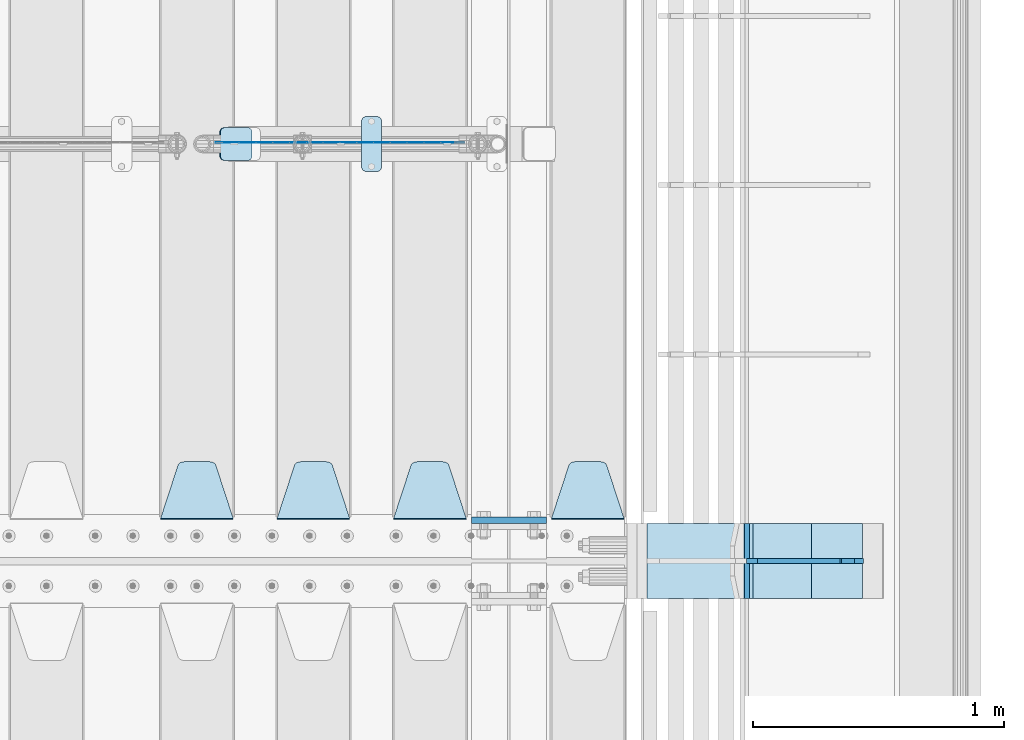
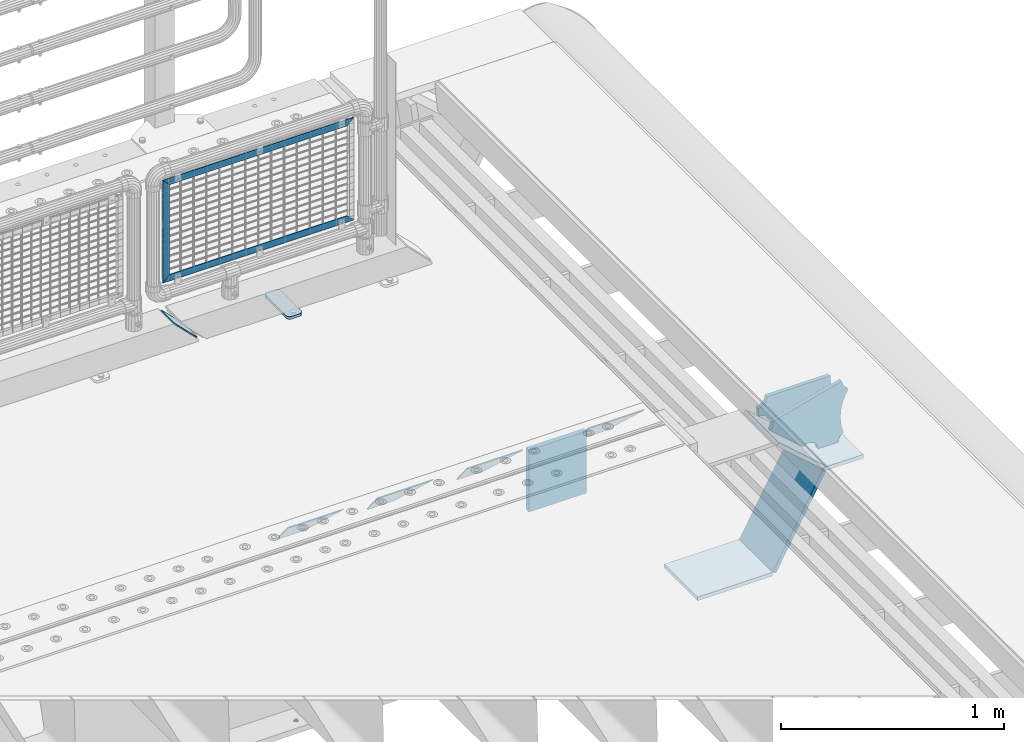
# One storey, part 191 of 208: 16 plates.
"""IFC2X3 building model written with IfcOpenShell, lengths in millimetres."""

from ifc_helpers import new_model, si_unit, frame, origin_with_axes, place, context, subcontext, project, spatial, faceted_brep, material, type_object, element, save


model = new_model("IFC2X3")

# Units and contexts
model_context = context("Model", 3, precision=1e-05, world=origin_with_axes())
body_context = subcontext(model_context, "Body", "Model", "MODEL_VIEW")
ifc_project = project(units=[si_unit("LENGTHUNIT", "METRE", prefix="MILLI"), si_unit("AREAUNIT", "SQUARE_METRE"), si_unit("VOLUMEUNIT", "CUBIC_METRE"), si_unit("MASSUNIT", "GRAM", prefix="KILO"), si_unit("TIMEUNIT", "SECOND"), si_unit("PLANEANGLEUNIT", "RADIAN"), si_unit("SOLIDANGLEUNIT", "STERADIAN"), si_unit("THERMODYNAMICTEMPERATUREUNIT", "DEGREE_CELSIUS"), si_unit("LUMINOUSINTENSITYUNIT", "LUMEN")], contexts=[model_context])

# Site, building, storey
site_placement = place(None, origin_with_axes())
site = spatial("IfcSite", under=ifc_project, at=site_placement, CompositionType="ELEMENT")
building_placement = place(site_placement, origin_with_axes())
building = spatial("IfcBuilding", under=site, at=building_placement, Name="Standard", CompositionType="ELEMENT")
storey_placement = place(building_placement, origin_with_axes())
storey = spatial("IfcBuildingStorey", under=building, at=storey_placement, Name="Undefined", CompositionType="ELEMENT", Elevation=0.0)

# Plates
ifc_material_1 = material(Name="STEEL/S355N")
plate_type_1 = type_object("IfcPlateType", PredefinedType="NOTDEFINED")
plate_1_placement = place(storey_placement, frame((-26255.0, 3162.5, -340.000000000044), z_axis=(0.0, 0.0, 1.0), x_axis=(1.0, 0.0, 0.0)))
element("IfcPlate", 1, at=plate_1_placement, inside=storey, type_object=plate_type_1, material=ifc_material_1, context=body_context, shape_type="Brep", body=[
    faceted_brep([(0.0, -12.5, 0.0), (0.0, -12.5, 340.0), (0.0, 12.5, 340.0), (0.0, 12.5, 0.0), (300.0, -12.5, 340.0), (300.0, 12.5, 340.0), (300.0, -12.5, 0.0), (300.0, 12.5, 0.0)], [[[0, 1, 2, 3]], [[1, 4, 5, 2]], [[4, 6, 7, 5]], [[6, 0, 3, 7]], [[5, 7, 3, 2]], [[6, 4, 1, 0]]]),
])
ifc_material_2 = material(Name="STEEL/S355J2")
plate_type_2 = type_object("IfcPlateType", PredefinedType="NOTDEFINED")
plate_2_placement = place(storey_placement, frame((-26693.0, 4774.5, 21.0199999999977), z_axis=(1.0, 0.0, 0.0), x_axis=(0.0, -1.0, 0.0)))
element("IfcPlate", 2, at=plate_2_placement, inside=storey, type_object=plate_type_2, material=ifc_material_2, context=body_context, shape_type="Brep", body=[
    faceted_brep([(0.0, -7.0, 20.0), (0.0, -7.0, 60.0), (0.0, 7.0, 60.0), (0.0, 7.0, 20.0), (0.384294391935327, -7.0, 63.9018064403208), (0.384294391935327, 7.0, 63.9018064403208), (1.52240934977453, -7.0, 67.6536686473009), (1.52240934977453, 7.0, 67.6536686473009), (3.37060775394912, -7.0, 71.1114046603907), (3.37060775394912, 7.0, 71.1114046603907), (5.85786437626939, -7.0, 74.1421356237297), (5.85786437626939, 7.0, 74.1421356237297), (8.8885953396084, -7.0, 76.62939224605), (8.8885953396084, 7.0, 76.62939224605), (12.3463313526981, -7.0, 78.4775906502255), (12.3463313526981, 7.0, 78.4775906502255), (16.0981935596774, -7.0, 79.6157056080629), (16.0981935596774, 7.0, 79.6157056080629), (20.0, -7.0, 80.0), (20.0, 7.0, 80.0), (200.0, -7.0, 80.0), (200.0, 7.0, 80.0), (203.901806440323, -7.0, 79.6157056080629), (203.901806440323, 7.0, 79.6157056080629), (207.653668647302, -7.0, 78.4775906502255), (207.653668647302, 7.0, 78.4775906502255), (211.111404660393, -7.0, 76.62939224605), (211.111404660393, 7.0, 76.62939224605), (214.142135623731, -7.0, 74.1421356237297), (214.142135623731, 7.0, 74.1421356237297), (216.629392246051, -7.0, 71.1114046603907), (216.629392246051, 7.0, 71.1114046603907), (218.477590650225, -7.0, 67.6536686473009), (218.477590650225, 7.0, 67.6536686473009), (219.615705608065, -7.0, 63.9018064403208), (219.615705608065, 7.0, 63.9018064403208), (220.0, -7.0, 60.0), (220.0, 7.0, 60.0), (220.0, -7.0, 20.0), (220.0, 7.0, 20.0), (219.615705608065, -7.0, 16.0981935596792), (219.615705608065, 7.0, 16.0981935596792), (218.477590650225, -7.0, 12.3463313526991), (218.477590650225, 7.0, 12.3463313526991), (216.629392246051, -7.0, 8.88859533960931), (216.629392246051, 7.0, 8.88859533960931), (214.142135623731, -7.0, 5.8578643762703), (214.142135623731, 7.0, 5.8578643762703), (211.111404660393, -7.0, 3.37060775395003), (211.111404660393, 7.0, 3.37060775395003), (207.653668647302, -7.0, 1.52240934977453), (207.653668647302, 7.0, 1.52240934977453), (203.901806440323, -7.0, 0.384294391937146), (203.901806440323, 7.0, 0.384294391937146), (200.0, -7.0, 0.0), (200.0, 7.0, 0.0), (20.0, -7.0, 0.0), (20.0, 7.0, 0.0), (16.0981935596774, -7.0, 0.384294391937146), (16.0981935596774, 7.0, 0.384294391937146), (12.3463313526981, -7.0, 1.52240934977453), (12.3463313526981, 7.0, 1.52240934977453), (8.8885953396084, -7.0, 3.37060775395003), (8.8885953396084, 7.0, 3.37060775395003), (5.85786437626939, -7.0, 5.8578643762703), (5.85786437626939, 7.0, 5.8578643762703), (3.37060775394912, -7.0, 8.88859533960931), (3.37060775394912, 7.0, 8.88859533960931), (1.52240934977453, -7.0, 12.3463313526991), (1.52240934977453, 7.0, 12.3463313526991), (0.384294391935327, -7.0, 16.0981935596792), (0.384294391935327, 7.0, 16.0981935596792)], [[[0, 1, 2, 3]], [[1, 4, 5, 2]], [[4, 6, 7, 5]], [[6, 8, 9, 7]], [[8, 10, 11, 9]], [[10, 12, 13, 11]], [[12, 14, 15, 13]], [[14, 16, 17, 15]], [[16, 18, 19, 17]], [[18, 20, 21, 19]], [[20, 22, 23, 21]], [[22, 24, 25, 23]], [[24, 26, 27, 25]], [[26, 28, 29, 27]], [[28, 30, 31, 29]], [[30, 32, 33, 31]], [[32, 34, 35, 33]], [[34, 36, 37, 35]], [[36, 38, 39, 37]], [[38, 40, 41, 39]], [[40, 42, 43, 41]], [[42, 44, 45, 43]], [[44, 46, 47, 45]], [[46, 48, 49, 47]], [[48, 50, 51, 49]], [[50, 52, 53, 51]], [[52, 54, 55, 53]], [[54, 56, 57, 55]], [[56, 58, 59, 57]], [[58, 60, 61, 59]], [[60, 62, 63, 61]], [[62, 64, 65, 63]], [[64, 66, 67, 65]], [[66, 68, 69, 67]], [[68, 70, 71, 69]], [[70, 0, 3, 71]], [[5, 7, 9, 11, 13, 15, 17, 19, 21, 23, 25, 27, 29, 31, 33, 35, 37, 39, 41, 43, 45, 47, 49, 51, 53, 55, 57, 59, 61, 63, 65, 67, 69, 71, 3, 2]], [[70, 68, 66, 64, 62, 60, 58, 56, 54, 52, 50, 48, 46, 44, 42, 40, 38, 36, 34, 32, 30, 28, 26, 24, 22, 20, 18, 16, 14, 12, 10, 8, 6, 4, 1, 0]]]),
])
plate_type_3 = type_object("IfcPlateType", PredefinedType="NOTDEFINED")
plate_3_placement = place(storey_placement, frame((-25645.0, 3168.23223304702, -1.76776695296758), z_axis=(0.0, 0.707106781186547, -0.707106781186548), x_axis=(-1.0, 0.0, 0.0)))
element("IfcPlate", 3, at=plate_3_placement, inside=storey, type_object=plate_type_3, material=ifc_material_1, context=body_context, shape_type="Brep", body=[
    faceted_brep([(0.0, -2.5, 0.0), (69.345504679477, -2.5, 300.17173142483), (69.345504679477, 2.5, 300.17173142483), (0.0, 2.5, 0.0), (70.9274061199576, -2.5, 304.897442415399), (70.9274061199576, 2.5, 304.8974424154), (73.3818627772307, -2.5, 309.234538108527), (73.3818627772307, 2.5, 309.234538108527), (76.6187032999551, -2.5, 313.023683126103), (76.6187032999551, 2.5, 313.023683126103), (80.5190132704993, -2.5, 316.125672595371), (80.5190132704993, 2.5, 316.125672595371), (84.9395038596849, -2.5, 318.426546230476), (84.9395038596849, 2.50000000000091, 318.426546230476), (89.7177759439219, -2.5, 319.841774983275), (89.7177759439219, 2.50000000000091, 319.841774983275), (94.678286292652, -2.49999999999909, 320.319366455078), (94.678286292652, 2.5, 320.319366455078), (195.321713707348, -2.49999999999909, 320.319366455078), (195.321713707348, 2.5, 320.319366455078), (200.282224056078, -2.5, 319.841774983275), (200.282224056078, 2.5, 319.841774983274), (205.060496140315, -2.5, 318.426546230475), (205.060496140315, 2.5, 318.426546230475), (209.480986729501, -2.5, 316.125672595371), (209.480986729501, 2.50000000000091, 316.125672595371), (213.381296700045, -2.5, 313.023683126102), (213.381296700045, 2.5, 313.023683126102), (216.618137222769, -2.5, 309.234538108526), (216.618137222769, 2.5, 309.234538108527), (219.072593880042, -2.5, 304.897442415399), (219.072593880042, 2.5, 304.897442415399), (220.654495320523, -2.5, 300.17173142483), (220.654495320523, 2.5, 300.17173142483), (290.0, -2.5, 0.0), (290.0, 2.5, 0.0)], [[[0, 1, 2, 3]], [[1, 4, 5, 2]], [[4, 6, 7, 5]], [[6, 8, 9, 7]], [[8, 10, 11, 9]], [[10, 12, 13, 11]], [[12, 14, 15, 13]], [[14, 16, 17, 15]], [[16, 18, 19, 17]], [[18, 20, 21, 19]], [[20, 22, 23, 21]], [[22, 24, 25, 23]], [[24, 26, 27, 25]], [[26, 28, 29, 27]], [[28, 30, 31, 29]], [[30, 32, 33, 31]], [[32, 34, 35, 33]], [[34, 0, 3, 35]], [[5, 7, 9, 11, 13, 15, 17, 19, 21, 23, 25, 27, 29, 31, 33, 35, 3, 2]], [[34, 32, 30, 28, 26, 24, 22, 20, 18, 16, 14, 12, 10, 8, 6, 4, 1, 0]]]),
])
plate_4_placement = place(storey_placement, frame((-26275.0, 3168.23223304702, -1.76776695296758), z_axis=(0.0, 0.707106781186547, -0.707106781186548), x_axis=(-1.0, 0.0, 0.0)))
element("IfcPlate", 4, at=plate_4_placement, inside=storey, type_object=plate_type_3, material=ifc_material_1, context=body_context, shape_type="Brep", body=[
    faceted_brep([(0.0, -2.5, 0.0), (69.345504679477, -2.5, 300.17173142483), (69.345504679477, 2.5, 300.17173142483), (0.0, 2.5, 0.0), (70.9274061199576, -2.5, 304.897442415399), (70.9274061199576, 2.5, 304.8974424154), (73.3818627772307, -2.5, 309.234538108527), (73.3818627772307, 2.5, 309.234538108527), (76.6187032999551, -2.5, 313.023683126103), (76.6187032999551, 2.5, 313.023683126103), (80.5190132704993, -2.5, 316.125672595371), (80.5190132704993, 2.5, 316.125672595371), (84.9395038596849, -2.5, 318.426546230476), (84.9395038596849, 2.50000000000091, 318.426546230476), (89.7177759439219, -2.5, 319.841774983275), (89.7177759439219, 2.50000000000091, 319.841774983275), (94.678286292652, -2.49999999999909, 320.319366455078), (94.678286292652, 2.5, 320.319366455078), (195.321713707348, -2.49999999999909, 320.319366455078), (195.321713707348, 2.5, 320.319366455078), (200.282224056078, -2.5, 319.841774983275), (200.282224056078, 2.5, 319.841774983274), (205.060496140315, -2.5, 318.426546230475), (205.060496140315, 2.5, 318.426546230475), (209.480986729501, -2.5, 316.125672595371), (209.480986729501, 2.50000000000091, 316.125672595371), (213.381296700045, -2.5, 313.023683126102), (213.381296700045, 2.5, 313.023683126102), (216.618137222769, -2.5, 309.234538108526), (216.618137222769, 2.5, 309.234538108527), (219.072593880042, -2.5, 304.897442415399), (219.072593880042, 2.5, 304.897442415399), (220.654495320523, -2.5, 300.17173142483), (220.654495320523, 2.5, 300.17173142483), (290.0, -2.5, 0.0), (290.0, 2.5, 0.0)], [[[0, 1, 2, 3]], [[1, 4, 5, 2]], [[4, 6, 7, 5]], [[6, 8, 9, 7]], [[8, 10, 11, 9]], [[10, 12, 13, 11]], [[12, 14, 15, 13]], [[14, 16, 17, 15]], [[16, 18, 19, 17]], [[18, 20, 21, 19]], [[20, 22, 23, 21]], [[22, 24, 25, 23]], [[24, 26, 27, 25]], [[26, 28, 29, 27]], [[28, 30, 31, 29]], [[30, 32, 33, 31]], [[32, 34, 35, 33]], [[34, 0, 3, 35]], [[5, 7, 9, 11, 13, 15, 17, 19, 21, 23, 25, 27, 29, 31, 33, 35, 3, 2]], [[34, 32, 30, 28, 26, 24, 22, 20, 18, 16, 14, 12, 10, 8, 6, 4, 1, 0]]]),
])
plate_5_placement = place(storey_placement, frame((-26740.0, 3168.23223304702, -1.76776695296758), z_axis=(0.0, 0.707106781186547, -0.707106781186548), x_axis=(-1.0, 0.0, 0.0)))
element("IfcPlate", 5, at=plate_5_placement, inside=storey, type_object=plate_type_3, material=ifc_material_1, context=body_context, shape_type="Brep", body=[
    faceted_brep([(0.0, -2.5, 0.0), (69.345504679477, -2.5, 300.17173142483), (69.345504679477, 2.5, 300.17173142483), (0.0, 2.5, 0.0), (70.9274061199576, -2.5, 304.897442415399), (70.9274061199576, 2.5, 304.8974424154), (73.3818627772307, -2.5, 309.234538108527), (73.3818627772307, 2.5, 309.234538108527), (76.6187032999551, -2.5, 313.023683126103), (76.6187032999551, 2.5, 313.023683126103), (80.5190132704993, -2.5, 316.125672595371), (80.5190132704993, 2.5, 316.125672595371), (84.9395038596849, -2.5, 318.426546230476), (84.9395038596849, 2.50000000000091, 318.426546230476), (89.7177759439219, -2.5, 319.841774983275), (89.7177759439219, 2.50000000000091, 319.841774983275), (94.678286292652, -2.49999999999909, 320.319366455078), (94.678286292652, 2.5, 320.319366455078), (195.321713707348, -2.49999999999909, 320.319366455078), (195.321713707348, 2.5, 320.319366455078), (200.282224056078, -2.5, 319.841774983275), (200.282224056078, 2.5, 319.841774983274), (205.060496140315, -2.5, 318.426546230475), (205.060496140315, 2.5, 318.426546230475), (209.480986729501, -2.5, 316.125672595371), (209.480986729501, 2.50000000000091, 316.125672595371), (213.381296700045, -2.5, 313.023683126102), (213.381296700045, 2.5, 313.023683126102), (216.618137222769, -2.5, 309.234538108526), (216.618137222769, 2.5, 309.234538108527), (219.072593880042, -2.5, 304.897442415399), (219.072593880042, 2.5, 304.897442415399), (220.654495320523, -2.5, 300.17173142483), (220.654495320523, 2.5, 300.17173142483), (290.0, -2.5, 0.0), (290.0, 2.5, 0.0)], [[[0, 1, 2, 3]], [[1, 4, 5, 2]], [[4, 6, 7, 5]], [[6, 8, 9, 7]], [[8, 10, 11, 9]], [[10, 12, 13, 11]], [[12, 14, 15, 13]], [[14, 16, 17, 15]], [[16, 18, 19, 17]], [[18, 20, 21, 19]], [[20, 22, 23, 21]], [[22, 24, 25, 23]], [[24, 26, 27, 25]], [[26, 28, 29, 27]], [[28, 30, 31, 29]], [[30, 32, 33, 31]], [[32, 34, 35, 33]], [[34, 0, 3, 35]], [[5, 7, 9, 11, 13, 15, 17, 19, 21, 23, 25, 27, 29, 31, 33, 35, 3, 2]], [[34, 32, 30, 28, 26, 24, 22, 20, 18, 16, 14, 12, 10, 8, 6, 4, 1, 0]]]),
])
plate_6_placement = place(storey_placement, frame((-27205.0, 3168.23223304702, -1.76776695296758), z_axis=(0.0, 0.707106781186547, -0.707106781186548), x_axis=(-1.0, 0.0, 0.0)))
element("IfcPlate", 6, at=plate_6_placement, inside=storey, type_object=plate_type_3, material=ifc_material_1, context=body_context, shape_type="Brep", body=[
    faceted_brep([(0.0, -2.5, 0.0), (69.345504679477, -2.5, 300.17173142483), (69.345504679477, 2.5, 300.17173142483), (0.0, 2.5, 0.0), (70.9274061199576, -2.5, 304.897442415399), (70.9274061199576, 2.5, 304.8974424154), (73.3818627772307, -2.5, 309.234538108527), (73.3818627772307, 2.5, 309.234538108527), (76.6187032999551, -2.5, 313.023683126103), (76.6187032999551, 2.5, 313.023683126103), (80.5190132704993, -2.5, 316.125672595371), (80.5190132704993, 2.5, 316.125672595371), (84.9395038596849, -2.5, 318.426546230476), (84.9395038596849, 2.50000000000091, 318.426546230476), (89.7177759439219, -2.5, 319.841774983275), (89.7177759439219, 2.50000000000091, 319.841774983275), (94.678286292652, -2.49999999999909, 320.319366455078), (94.678286292652, 2.5, 320.319366455078), (195.321713707348, -2.49999999999909, 320.319366455078), (195.321713707348, 2.5, 320.319366455078), (200.282224056078, -2.5, 319.841774983275), (200.282224056078, 2.5, 319.841774983274), (205.060496140315, -2.5, 318.426546230475), (205.060496140315, 2.5, 318.426546230475), (209.480986729501, -2.5, 316.125672595371), (209.480986729501, 2.50000000000091, 316.125672595371), (213.381296700045, -2.5, 313.023683126102), (213.381296700045, 2.5, 313.023683126102), (216.618137222769, -2.5, 309.234538108526), (216.618137222769, 2.5, 309.234538108527), (219.072593880042, -2.5, 304.897442415399), (219.072593880042, 2.5, 304.897442415399), (220.654495320523, -2.5, 300.17173142483), (220.654495320523, 2.5, 300.17173142483), (290.0, -2.5, 0.0), (290.0, 2.5, 0.0)], [[[0, 1, 2, 3]], [[1, 4, 5, 2]], [[4, 6, 7, 5]], [[6, 8, 9, 7]], [[8, 10, 11, 9]], [[10, 12, 13, 11]], [[12, 14, 15, 13]], [[14, 16, 17, 15]], [[16, 18, 19, 17]], [[18, 20, 21, 19]], [[20, 22, 23, 21]], [[22, 24, 25, 23]], [[24, 26, 27, 25]], [[26, 28, 29, 27]], [[28, 30, 31, 29]], [[30, 32, 33, 31]], [[32, 34, 35, 33]], [[34, 0, 3, 35]], [[5, 7, 9, 11, 13, 15, 17, 19, 21, 23, 25, 27, 29, 31, 33, 35, 3, 2]], [[34, 32, 30, 28, 26, 24, 22, 20, 18, 16, 14, 12, 10, 8, 6, 4, 1, 0]]]),
])
ifc_material_3 = material(Name="Misc_Undefined")
plate_type_4 = type_object("IfcPlateType", PredefinedType="NOTDEFINED")
plate_7_placement = place(storey_placement, frame((-27239.8899741176, 4670.4999645044, 879.520017263591), z_axis=(-0.707106781186548, 0.0, -0.707106781186548), x_axis=(-0.707106781186548, 0.0, 0.707106781186548)))
element("IfcPlate", 7, at=plate_7_placement, inside=storey, type_object=plate_type_4, material=ifc_material_3, context=body_context, shape_type="Brep", body=[
    faceted_brep([(0.0, -1.49999999999909, 3.63797880709171e-12), (-348.603637695382, -1.5, 348.603668212891), (-348.603637695378, 1.50000000000091, 348.603668212894), (0.0, 1.50000000000182, 3.63797880709171e-12), (-348.603637695389, -1.49999999999909, 398.101165771488), (-348.603637695393, 1.50000000000091, 398.101165771484), (49.4974975585938, -1.5, 2.18278728425503e-11), (49.4974975585938, 1.50000000000091, 2.5465851649642e-11)], [[[0, 1, 2, 3]], [[1, 4, 5, 2]], [[4, 6, 7, 5]], [[6, 0, 3, 7]], [[5, 7, 3, 2]], [[6, 4, 1, 0]]]),
])
plate_8_placement = place(storey_placement, frame((-27239.8899996664, 4670.49998832922, 386.520006105212), z_axis=(0.707106781186548, 0.0, -0.707106781186548), x_axis=(-0.707106781186548, 0.0, -0.707106781186548)))
element("IfcPlate", 8, at=plate_8_placement, inside=storey, type_object=plate_type_4, material=ifc_material_3, context=body_context, shape_type="Brep", body=[
    faceted_brep([(0.0, -1.49999999999909, 3.63797880709171e-12), (-651.521057128917, -1.5, 651.521179199215), (-651.521057128917, 1.49999999999909, 651.521179199219), (0.0, 1.50000000000182, 3.63797880709171e-12), (-651.521057128921, -1.5, 701.018676757809), (-651.521057128917, 1.5, 701.018676757813), (49.4974975585938, -1.5, 2.18278728425503e-11), (49.4974975585938, 1.50000000000091, 2.5465851649642e-11)], [[[0, 1, 2, 3]], [[1, 4, 5, 2]], [[4, 6, 7, 5]], [[6, 0, 3, 7]], [[5, 7, 3, 2]], [[6, 4, 1, 0]]]),
])
plate_9_placement = place(storey_placement, frame((-26283.5000006033, 4670.49978377061, 914.520000514843), z_axis=(-0.707106781186548, 0.0, 0.707106781186548), x_axis=(-0.707106781186548, 0.0, -0.707106781186548)))
element("IfcPlate", 9, at=plate_9_placement, inside=storey, type_object=plate_type_4, material=ifc_material_3, context=body_context, shape_type="Brep", body=[
    faceted_brep([(0.0, -1.49999999999909, 3.63797880709171e-12), (701.018554687544, -1.50000000000091, 701.018615722656), (701.018554687544, 1.49999999999909, 701.01861572266), (0.0, 1.50000000000182, 3.63797880709171e-12), (701.01855468754, -1.5, 651.521118164066), (701.01855468754, 1.49999999999909, 651.521118164066), (49.4974975585938, -1.5, 2.18278728425503e-11), (49.4974975585938, 1.50000000000091, 2.5465851649642e-11)], [[[0, 1, 2, 3]], [[1, 4, 5, 2]], [[4, 6, 7, 5]], [[6, 0, 3, 7]], [[5, 7, 3, 2]], [[6, 4, 1, 0]]]),
])
plate_type_5 = type_object("IfcPlateType", PredefinedType="NOTDEFINED")
plate_10_placement = place(storey_placement, frame((-27257.807581521, 4729.5, 166.254400376567), z_axis=(0.707410512925777, 0.0, -0.706802918925841), x_axis=(0.0, -1.0, 0.0)))
element("IfcPlate", 10, at=plate_10_placement, inside=storey, type_object=plate_type_5, material=ifc_material_2, context=body_context, shape_type="Brep", body=[
    faceted_brep([(0.0, -2.49999999999636, 20.0000000000036), (0.0, -2.49999999999636, 158.92665100098), (0.0, 2.5, 158.92665100098), (0.0, 2.50000000000364, 20.0000000000036), (0.384294391935327, -2.5, 162.828457441301), (0.384294391935327, 2.50000000000364, 162.828457441305), (1.52240934977453, -2.49999999999636, 166.580319648281), (1.52240934977453, 2.50000000000364, 166.580319648281), (3.37060775394912, -2.49999999999636, 170.038055661371), (3.37060775394912, 2.50000000000364, 170.038055661375), (5.85786437626939, -2.49999999999636, 173.06878662471), (5.85786437626939, 2.50000000000364, 173.06878662471), (8.8885953396084, -2.5, 175.55604324703), (8.8885953396084, 2.5, 175.55604324703), (12.3463313526981, -2.49999999999636, 177.404241651206), (12.3463313526981, 2.50000000000364, 177.404241651206), (16.0981935596774, -2.5, 178.542356609047), (16.0981935596774, 2.50000000000364, 178.542356609043), (20.0, -2.49999999999272, 178.92665100098), (20.0, 2.50000000000364, 178.92665100098), (110.0, -2.49999999999272, 178.92665100098), (110.0, 2.50000000000364, 178.92665100098), (113.901806440323, -2.5, 178.542356609047), (113.901806440323, 2.50000000000364, 178.542356609043), (117.653668647302, -2.49999999999636, 177.404241651206), (117.653668647302, 2.50000000000364, 177.404241651206), (121.111404660392, -2.5, 175.55604324703), (121.111404660392, 2.5, 175.55604324703), (124.142135623731, -2.49999999999636, 173.06878662471), (124.142135623731, 2.50000000000364, 173.06878662471), (126.629392246051, -2.49999999999636, 170.038055661371), (126.629392246051, 2.50000000000364, 170.038055661375), (128.477590650225, -2.49999999999636, 166.580319648281), (128.477590650225, 2.50000000000364, 166.580319648281), (129.615705608065, -2.5, 162.828457441301), (129.615705608065, 2.50000000000364, 162.828457441305), (130.0, -2.49999999999636, 158.92665100098), (130.0, 2.5, 158.92665100098), (130.0, -2.49999999999636, 20.0000000000036), (130.0, 2.50000000000364, 20.0000000000036), (129.615705608065, -2.49999999999636, 16.0981935596792), (129.615705608065, 2.50000000000364, 16.0981935596792), (128.477590650225, -2.49999999999636, 12.3463313526991), (128.477590650225, 2.50000000000364, 12.3463313526991), (126.629392246051, -2.49999999999636, 8.88859533961295), (126.629392246051, 2.5, 8.88859533960931), (124.142135623731, -2.49999999999636, 5.85786437627394), (124.142135623731, 2.5, 5.85786437627394), (121.111404660392, -2.49999999999636, 3.37060775395003), (121.111404660392, 2.50000000000364, 3.37060775395003), (117.653668647302, -2.5, 1.52240934977453), (117.653668647302, 2.50000000000364, 1.52240934977817), (113.901806440323, -2.49999999999636, 0.384294391937146), (113.901806440323, 2.50000000000364, 0.384294391937146), (110.0, -2.5, 7.27595761418343e-12), (110.0, 2.50000000000364, 3.63797880709171e-12), (20.0, -2.5, 7.27595761418343e-12), (20.0, 2.50000000000364, 3.63797880709171e-12), (16.0981935596774, -2.49999999999636, 0.384294391937146), (16.0981935596774, 2.50000000000364, 0.384294391937146), (12.3463313526981, -2.5, 1.52240934977453), (12.3463313526981, 2.50000000000364, 1.52240934977817), (8.8885953396084, -2.49999999999636, 3.37060775395003), (8.8885953396084, 2.50000000000364, 3.37060775395003), (5.85786437626939, -2.49999999999636, 5.85786437627394), (5.85786437626939, 2.5, 5.85786437627394), (3.37060775394912, -2.49999999999636, 8.88859533961295), (3.37060775394912, 2.5, 8.88859533960931), (1.52240934977453, -2.49999999999636, 12.3463313526991), (1.52240934977453, 2.50000000000364, 12.3463313526991), (0.384294391935327, -2.49999999999636, 16.0981935596792), (0.384294391935327, 2.50000000000364, 16.0981935596792)], [[[0, 1, 2, 3]], [[1, 4, 5, 2]], [[4, 6, 7, 5]], [[6, 8, 9, 7]], [[8, 10, 11, 9]], [[10, 12, 13, 11]], [[12, 14, 15, 13]], [[14, 16, 17, 15]], [[16, 18, 19, 17]], [[18, 20, 21, 19]], [[20, 22, 23, 21]], [[22, 24, 25, 23]], [[24, 26, 27, 25]], [[26, 28, 29, 27]], [[28, 30, 31, 29]], [[30, 32, 33, 31]], [[32, 34, 35, 33]], [[34, 36, 37, 35]], [[36, 38, 39, 37]], [[38, 40, 41, 39]], [[40, 42, 43, 41]], [[42, 44, 45, 43]], [[44, 46, 47, 45]], [[46, 48, 49, 47]], [[48, 50, 51, 49]], [[50, 52, 53, 51]], [[52, 54, 55, 53]], [[54, 56, 57, 55]], [[56, 58, 59, 57]], [[58, 60, 61, 59]], [[60, 62, 63, 61]], [[62, 64, 65, 63]], [[64, 66, 67, 65]], [[66, 68, 69, 67]], [[68, 70, 71, 69]], [[70, 0, 3, 71]], [[5, 7, 9, 11, 13, 15, 17, 19, 21, 23, 25, 27, 29, 31, 33, 35, 37, 39, 41, 43, 45, 47, 49, 51, 53, 55, 57, 59, 61, 63, 65, 67, 69, 71, 3, 2]], [[70, 68, 66, 64, 62, 60, 58, 56, 54, 52, 50, 48, 46, 44, 42, 40, 38, 36, 34, 32, 30, 28, 26, 24, 22, 20, 18, 16, 14, 12, 10, 8, 6, 4, 1, 0]]]),
])
plate_type_6 = type_object("IfcPlateType", PredefinedType="NOTDEFINED")
plate_11_placement = place(storey_placement, frame((-24609.0011497488, 2999.99999999933, -28.9999913318487), z_axis=(0.260769276985653, 0.0, -0.965401151946889), x_axis=(-0.965401151946889, 0.0, -0.260769276985654)))
element("IfcPlate", 11, at=plate_11_placement, inside=storey, type_object=plate_type_6, material=ifc_material_1, context=body_context, shape_type="Brep", body=[
    faceted_brep([(183.436474692327, 10.0, 275.852500330424), (184.918388609061, 10.0, 264.417843531322), (184.918388609061, -10.0, 264.417843531322), (183.436474692327, -10.0, 275.852500330424), (183.794583267616, 10.0, 224.576469334607), (183.794583267616, -10.0, 224.576469334607), (176.452049775839, 10.0, 185.401410454621), (176.452049775839, -10.0, 185.401410454621), (163.071585676771, 10.0, 147.857286855558), (163.071585676771, -10.0, 147.857286855558), (143.982662403749, 10.0, 112.868559462227), (143.982662403749, -10.0, 112.868559462227), (119.655312600255, 10.0, 81.2967668639831), (119.655312600255, -10.0, 81.2967668639831), (100.960891712752, 10.0, 63.6280409830933), (100.960891712752, -10.0, 63.6280409830933), (194.486836975906, -10.0, 278.751956446687), (207.178624553377, -10.0, 286.650994937514), (207.178624553377, 10.0, 286.650994937514), (194.486836975906, 10.0, 278.751956446687), (216.96801346945, -10.0, 297.948965801394), (216.96801346945, 10.0, 297.948965801394), (222.979925232867, -10.0, 311.635937633766), (222.979925232867, 10.0, 311.635937633766), (323.381647032766, -10.0, 284.515917834983), (323.381647032766, 10.0, 284.515917834983), (321.72061717734, -10.0, 268.853198956859), (321.72061717734, 10.0, 268.853198956859), (325.01434448114, -10.0, 253.450889283181), (325.01434448114, 10.0, 253.450889283181), (332.935986082484, -10.0, 239.837389469553), (332.935986082484, 10.0, 239.837389469553), (344.699462330093, -10.0, 229.363593146934), (344.699462330093, 10.0, 229.363593146934), (359.137460970807, -10.0, 223.0688351622), (359.137460970807, 10.0, 223.0688351622), (374.817271777687, -10.0, 221.57775639289), (374.817271777687, 10.0, 221.57775639289), (390.182952880859, -10.0, 225.038330078124), (390.182952880859, 10.0, 225.038330078124), (512.90906051303, -10.0, 41.5599003357011), (512.90906051303, 10.0, 41.5599003357011), (503.648024844584, -10.0, 33.5643666747665), (503.648024844584, 10.0, 33.5643666747665), (496.606064569707, -10.0, 23.5590612989981), (496.606064569707, 10.0, 23.5590612989981), (492.204839143935, -10.0, 12.1430832451069), (492.204839143935, 10.0, 12.1430832451069), (490.707885742188, -10.0, 3.79259290639311e-10), (490.707885742188, 10.0, 3.79259290639311e-10), (120.0, -10.0, 9.18589648790658e-11), (120.0, 10.0, 9.18589648790658e-11), (117.226254779114, -10.0, 25.6516118492136), (117.226254779114, 10.0, 25.6516118492136), (109.03324682566, -10.0, 50.1173731020972), (109.03324682566, 10.0, 50.1173731020972)], [[[0, 1, 2, 3]], [[4, 5, 2, 1]], [[6, 7, 5, 4]], [[8, 9, 7, 6]], [[10, 11, 9, 8]], [[12, 13, 11, 10]], [[14, 15, 13, 12]], [[16, 17, 18, 19]], [[17, 20, 21, 18]], [[20, 22, 23, 21]], [[22, 24, 25, 23]], [[24, 26, 27, 25]], [[26, 28, 29, 27]], [[28, 30, 31, 29]], [[30, 32, 33, 31]], [[32, 34, 35, 33]], [[34, 36, 37, 35]], [[36, 38, 39, 37]], [[38, 40, 41, 39]], [[40, 42, 43, 41]], [[42, 44, 45, 43]], [[44, 46, 47, 45]], [[46, 48, 49, 47]], [[48, 50, 51, 49]], [[50, 52, 53, 51]], [[52, 54, 55, 53]], [[10, 8, 6, 4, 1, 0, 19, 18, 21, 23, 25, 27, 29, 31, 33, 35, 37, 39, 41, 43, 45, 47, 49, 51, 53, 55, 14, 12]], [[16, 19, 0, 3]], [[54, 52, 50, 48, 46, 44, 42, 40, 38, 36, 34, 32, 30, 28, 26, 24, 22, 20, 17, 16, 3, 2, 5, 7, 9, 11, 13, 15]], [[55, 54, 15, 14]]]),
])
plate_type_7 = type_object("IfcPlateType", PredefinedType="NOTDEFINED")
plate_12_placement = place(storey_placement, frame((-25137.7739409557, 3149.99999999933, -177.219372761326), z_axis=(0.752414935148685, 0.0, -0.658689430130164), x_axis=(0.0, -1.0, 0.0)))
element("IfcPlate", 12, at=plate_12_placement, inside=storey, type_object=plate_type_7, material=ifc_material_1, context=body_context, shape_type="Brep", body=[
    faceted_brep([(0.0, -10.0, 0.0), (1.09139364212751e-10, -9.99999999999636, 320.000000000004), (1.09139364212751e-10, 10.0000000000036, 320.0), (0.0, 10.0, 0.0), (300.0, -9.99999999999636, 320.000000000004), (300.0, 10.0000000000036, 320.0), (300.0, -10.0, 6.91215973347425e-11), (300.0, 10.0000000000036, 6.91215973347425e-11)], [[[0, 1, 2, 3]], [[1, 4, 5, 2]], [[4, 6, 7, 5]], [[6, 0, 3, 7]], [[5, 7, 3, 2]], [[6, 4, 1, 0]]]),
])
plate_13_placement = place(storey_placement, frame((-24896.9992711892, 3150.00000000007, -408.004820491625), z_axis=(-0.484064236150485, 0.0, -0.875032465272031), x_axis=(0.0, -1.0, 0.0)))
element("IfcPlate", 13, at=plate_13_placement, inside=storey, type_object=plate_type_7, material=ifc_material_1, context=body_context, shape_type="Brep", body=[
    faceted_brep([(0.0, -10.0, 0.0), (3.86515239370056e-07, -10.0, 533.528442382813), (3.86515239370056e-07, 9.99999999999636, 533.528442382809), (0.0, 10.0, 0.0), (300.003295898438, -10.0, 533.549133300779), (300.003295898438, 9.99999999999636, 533.549133300779), (300.0, -10.0, 6.91215973347425e-11), (300.0, 10.0000000000036, 6.91215973347425e-11)], [[[0, 1, 2, 3]], [[1, 4, 5, 2]], [[4, 6, 7, 5]], [[6, 0, 3, 7]], [[5, 7, 3, 2]], [[6, 4, 1, 0]]]),
])
plate_14_placement = place(storey_placement, frame((-25553.0011701087, 3150.00000000007, -879.999999999866), z_axis=(0.0, -1.0, 0.0), x_axis=(1.0, 0.0, 0.0)))
element("IfcPlate", 14, at=plate_14_placement, inside=storey, type_object=plate_type_7, material=ifc_material_1, context=body_context, shape_type="Brep", body=[
    faceted_brep([(0.0, -10.0, 0.0), (-1.98269844986498e-10, -10.0, 300.0), (-1.98269844986498e-10, 10.0000000000036, 300.0), (0.0, 10.0, 0.0), (389.0, -10.0, 300.0), (389.0, 10.0, 300.0), (389.0, -10.0, 0.0), (389.0, 10.0, 0.0)], [[[0, 1, 2, 3]], [[1, 4, 5, 2]], [[4, 6, 7, 5]], [[6, 0, 3, 7]], [[5, 7, 3, 2]], [[6, 4, 1, 0]]]),
])
plate_type_8 = type_object("IfcPlateType", PredefinedType="NOTDEFINED")
plate_15_placement = place(storey_placement, frame((-24693.0011701087, 3149.99999999933, -397.999999999763), z_axis=(-1.0, 0.0, 0.0), x_axis=(0.0, -1.0, 0.0)))
element("IfcPlate", 15, at=plate_15_placement, inside=storey, type_object=plate_type_8, material=ifc_material_1, context=body_context, shape_type="Brep", body=[
    faceted_brep([(0.0, -10.0, 0.0), (4.63842297904193e-10, -10.0, 204.0), (4.63842297904193e-10, 10.0, 204.0), (0.0, 10.0, 0.0), (300.0, -10.0, 204.0), (300.0, 10.0, 204.0), (300.0, -10.0, 6.91215973347425e-11), (300.0, 10.0000000000036, 6.91215973347425e-11)], [[[0, 1, 2, 3]], [[1, 4, 5, 2]], [[4, 6, 7, 5]], [[6, 0, 3, 7]], [[5, 7, 3, 2]], [[6, 4, 1, 0]]]),
])
plate_type_9 = type_object("IfcPlateType", PredefinedType="NOTDEFINED")
plate_16_placement = place(storey_placement, frame((-24614.0011701094, 3000.0, -9.99999999999716), z_axis=(0.0, 0.0, -1.0), x_axis=(-1.0, 0.0, 0.0)))
element("IfcPlate", 16, at=plate_16_placement, inside=storey, type_object=plate_type_9, material=ifc_material_1, context=body_context, shape_type="Brep", body=[
    faceted_brep([(164.157641141064, -10.0, 44.1844865875018), (486.718340840864, -10.0, 131.004562768382), (486.718340840864, 10.0, 131.004562768382), (164.157641141064, 10.0, 44.1844865875018), (492.179177700767, -10.0, 118.185717565315), (492.179177700767, 10.0, 118.185717565315), (500.965368826703, -10.0, 107.371542744776), (500.965368826703, 10.0, 107.371542744776), (512.394601349042, -10.0, 99.4018391429503), (512.394601349042, 10.0, 99.4018391429503), (525.579310641864, -10.0, 94.8955133209048), (525.579310641864, 10.0, 94.8955133209048), (539.495606295339, -10.0, 94.2025148824028), (539.495606295339, 10.0, 94.2025148824028), (543.504393704661, -10.0, 49.7974851175972), (543.504393704661, 10.0, 49.7974851175972), (529.167086307516, -10.0, 46.3176139481669), (529.167086307516, 10.0, 46.3176139481669), (516.469507120331, -10.0, 38.8049999196639), (516.469507120331, 10.0, 38.8049999196639), (506.517198234546, -10.0, 27.9137449599276), (506.517198234546, 10.0, 27.9137449599276), (500.17667886756, -10.0, 14.592119649441), (500.17667886756, 10.0, 14.592119649441), (498.0, -10.0, 0.0), (498.0, 10.0, 0.0), (170.0, -10.0, 0.0), (170.0, 10.0, 0.0), (169.632873911985, -10.0, 11.1663820622718), (169.632873911985, 10.0, 11.1663820622718), (168.533081313406, -10.0, 22.2845350637931), (168.533081313406, 10.0, 22.2845350637931), (166.705372351957, -10.0, 33.3064382514178), (166.705372351957, 10.0, 33.3064382514178)], [[[0, 1, 2, 3]], [[1, 4, 5, 2]], [[4, 6, 7, 5]], [[6, 8, 9, 7]], [[8, 10, 11, 9]], [[10, 12, 13, 11]], [[12, 14, 15, 13]], [[14, 16, 17, 15]], [[16, 18, 19, 17]], [[18, 20, 21, 19]], [[20, 22, 23, 21]], [[22, 24, 25, 23]], [[24, 26, 27, 25]], [[26, 28, 29, 27]], [[28, 30, 31, 29]], [[30, 32, 33, 31]], [[32, 0, 3, 33]], [[5, 7, 9, 11, 13, 15, 17, 19, 21, 23, 25, 27, 29, 31, 33, 3, 2]], [[32, 30, 28, 26, 24, 22, 20, 18, 16, 14, 12, 10, 8, 6, 4, 1, 0]]]),
])

save(model, "model.ifc")
